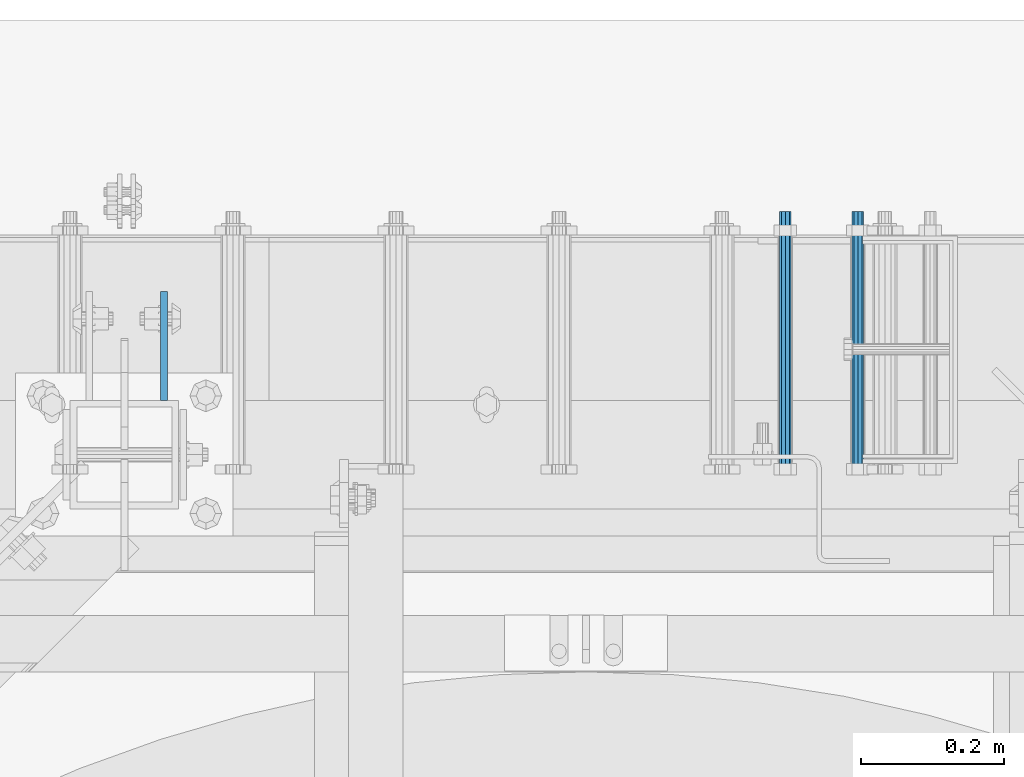
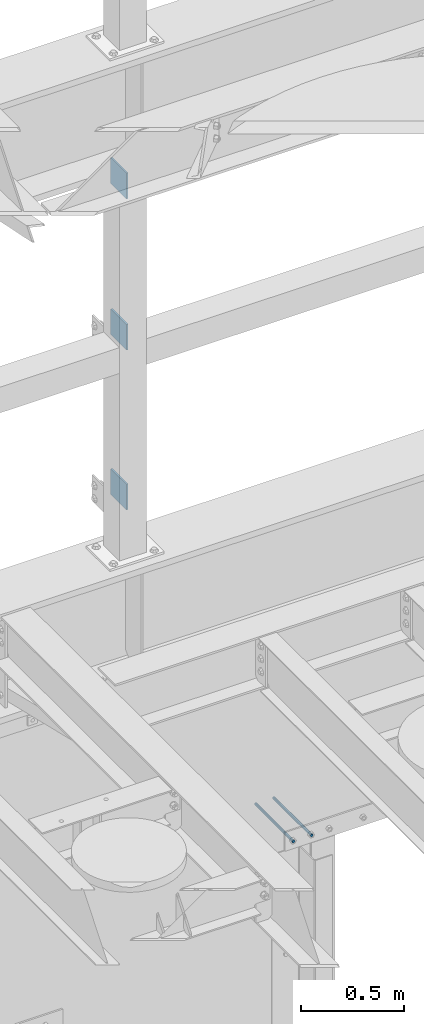
# One storey, part 1322 of 1876: 5 beams, 3 elements without a shape of their own.
"""IFC2X3 building model written with IfcOpenShell, lengths in millimetres."""

from ifc_helpers import new_model, si_unit, frame, origin_with_axes, place, context, subcontext, project, spatial, faceted_brep, material, type_object, element, aggregate, save


model = new_model("IFC2X3")

# Units and contexts
model_context = context("Model", 3, precision=1e-05, world=origin_with_axes())
body_context = subcontext(model_context, "Body", "Model", "MODEL_VIEW")
ifc_project = project(units=[si_unit("LENGTHUNIT", "METRE", prefix="MILLI"), si_unit("AREAUNIT", "SQUARE_METRE"), si_unit("VOLUMEUNIT", "CUBIC_METRE"), si_unit("MASSUNIT", "GRAM", prefix="KILO"), si_unit("TIMEUNIT", "SECOND"), si_unit("PLANEANGLEUNIT", "RADIAN"), si_unit("SOLIDANGLEUNIT", "STERADIAN"), si_unit("THERMODYNAMICTEMPERATUREUNIT", "DEGREE_CELSIUS"), si_unit("LUMINOUSINTENSITYUNIT", "LUMEN")], contexts=[model_context])

# Site, building, storey
site_placement = place(None, origin_with_axes())
site = spatial("IfcSite", under=ifc_project, at=site_placement, CompositionType="ELEMENT")
building_placement = place(site_placement, origin_with_axes())
building = spatial("IfcBuilding", under=site, at=building_placement, Name="Undefined", CompositionType="ELEMENT")
storey_placement = place(building_placement, origin_with_axes())
storey = spatial("IfcBuildingStorey", under=building, at=storey_placement, Name="Undefined", CompositionType="ELEMENT", Elevation=0.0)

# Assembly, beams
assembly_1_placement = place(storey_placement, origin_with_axes())
assembly_1 = element("IfcElementAssembly", 1, at=assembly_1_placement, inside=storey, Name="FRAME", AssemblyPlace="NOTDEFINED", PredefinedType="RIGID_FRAME")
ifc_material = material(Name="STEEL/A36")
beam_type_1 = type_object("IfcBeamType", PredefinedType="NOTDEFINED")
beam_1_placement = place(assembly_1_placement, frame((2595.55129445271, 13792.2, 7226.3), z_axis=(0.0, 0.0, -1.0), x_axis=(0.0, 1.0, 0.0)))
beam_1 = element("IfcBeam", 2, at=beam_1_placement, type_object=beam_type_1, material=ifc_material, Name="PLATE", context=body_context, shape_type="Brep", body=[
    faceted_brep([(0.0, 4.76249999999982, -76.1999999999998), (3.63797880709171e-12, 4.76249999999982, 76.1999969482422), (152.399993896484, 4.76250000000073, 76.1999969482422), (152.4, 4.76249999999982, -76.1999999999998), (3.63797880709171e-12, -4.76249999999982, 76.1999969482422), (152.399993896484, -4.76250000000073, 76.1999969482422), (0.0, -4.76249999999982, -76.1999999999998), (152.4, -4.76249999999982, -76.1999999999998)], [[[0, 1, 2, 3]], [[4, 5, 2, 1]], [[4, 6, 7, 5]], [[6, 0, 3, 7]], [[5, 7, 3, 2]], [[6, 4, 1, 0]]]),
])
beam_2_placement = place(assembly_1_placement, frame((2595.55129445271, 13792.2, 6330.95), z_axis=(0.0, 0.0, -1.0), x_axis=(0.0, 1.0, 0.0)))
beam_2 = element("IfcBeam", 3, at=beam_2_placement, type_object=beam_type_1, material=ifc_material, Name="PLATE", context=body_context, shape_type="Brep", body=[
    faceted_brep([(0.0, 4.76249999999982, -76.1999999999998), (3.63797880709171e-12, 4.76249999999982, 76.1999969482422), (152.399993896484, 4.76250000000073, 76.1999969482422), (152.4, 4.76249999999982, -76.1999999999998), (3.63797880709171e-12, -4.76249999999982, 76.1999969482422), (152.399993896484, -4.76250000000073, 76.1999969482422), (0.0, -4.76249999999982, -76.1999999999998), (152.4, -4.76249999999982, -76.1999999999998)], [[[0, 1, 2, 3]], [[4, 5, 2, 1]], [[4, 6, 7, 5]], [[6, 0, 3, 7]], [[5, 7, 3, 2]], [[6, 4, 1, 0]]]),
])
beam_3_placement = place(assembly_1_placement, frame((2595.55129445271, 13792.2, 5384.8), z_axis=(0.0, 0.0, -1.0), x_axis=(0.0, 1.0, 0.0)))
beam_3 = element("IfcBeam", 4, at=beam_3_placement, type_object=beam_type_1, material=ifc_material, Name="PLATE", context=body_context, shape_type="Brep", body=[
    faceted_brep([(0.0, 4.76249999999982, -76.1999999999998), (3.63797880709171e-12, 4.76249999999982, 76.1999969482422), (152.399993896484, 4.76250000000073, 76.1999969482422), (152.4, 4.76249999999982, -76.1999999999998), (3.63797880709171e-12, -4.76249999999982, 76.1999969482422), (152.399993896484, -4.76250000000073, 76.1999969482422), (0.0, -4.76249999999982, -76.1999999999998), (152.4, -4.76249999999982, -76.1999999999998)], [[[0, 1, 2, 3]], [[4, 5, 2, 1]], [[4, 6, 7, 5]], [[6, 0, 3, 7]], [[5, 7, 3, 2]], [[6, 4, 1, 0]]]),
])
aggregate(assembly_1, [beam_1, beam_2, beam_3])

# Assembly, beam
assembly_2_placement = place(storey_placement, origin_with_axes())
assembly_2 = element("IfcElementAssembly", 5, at=assembly_2_placement, inside=storey, Name="ANCHOR_BOLT", AssemblyPlace="NOTDEFINED", PredefinedType="RIGID_FRAME")
beam_type_2 = type_object("IfcBeamType", PredefinedType="NOTDEFINED")
beam_4_placement = place(assembly_2_placement, frame((3568.71071748669, 14057.3124966791, 3103.56250152592), z_axis=(0.0, 0.0, 1.0), x_axis=(-2.91149999864615e-05, -0.999999999576158, 0.0)))
beam_4 = element("IfcBeam", 6, at=beam_4_placement, type_object=beam_type_2, material=ifc_material, Name="ANCHOR_BOLT", context=body_context, shape_type="Brep", body=[
    faceted_brep([(0.0, -7.9375, 0.0), (0.0, -5.61266007566822, -5.61266007566883), (369.887490732475, -5.61266007567792, -5.61266007566837), (369.887490732477, -7.93750000000978, 0.0), (0.0, 0.0, -7.9375), (369.88749073247, -9.54969436861575e-12, -7.9375), (0.0, 5.61266007566822, -5.61266007566883), (369.887490732464, 5.6126600756586, -5.61266007566837), (0.0, 7.9375, 0.0), (369.887490732463, 7.93749999999045, 0.0), (0.0, 5.61266007566822, 5.61266007566883), (369.887490732464, 5.6126600756586, 5.61266007566837), (0.0, 0.0, 7.9375), (369.88749073247, -9.54969436861575e-12, 7.9375), (0.0, -5.61266007566822, 5.61266007566883), (369.887490732475, -5.61266007567792, 5.61266007566837)], [[[0, 1, 2, 3]], [[1, 4, 5, 2]], [[4, 6, 7, 5]], [[6, 8, 9, 7]], [[8, 10, 11, 9]], [[10, 12, 13, 11]], [[12, 14, 15, 13]], [[14, 0, 3, 15]], [[5, 7, 9, 11, 13, 15, 3, 2]], [[14, 12, 10, 8, 6, 4, 1, 0]]]),
])
aggregate(assembly_2, [beam_4])

assembly_3_placement = place(storey_placement, origin_with_axes())
assembly_3 = element("IfcElementAssembly", 7, at=assembly_3_placement, inside=storey, Name="ANCHOR_BOLT", AssemblyPlace="NOTDEFINED", PredefinedType="RIGID_FRAME")
beam_5_placement = place(assembly_3_placement, frame((3467.11071748669, 14057.3124966791, 3103.56250152592), z_axis=(0.0, 0.0, 1.0), x_axis=(-2.91149999864615e-05, -0.999999999576158, 0.0)))
beam_5 = element("IfcBeam", 8, at=beam_5_placement, type_object=beam_type_2, material=ifc_material, Name="ANCHOR_BOLT", context=body_context, shape_type="Brep", body=[
    faceted_brep([(0.0, -7.9375, 0.0), (0.0, -5.61266007566822, -5.61266007566883), (369.887490732475, -5.61266007567792, -5.61266007566837), (369.887490732477, -7.93750000000978, 0.0), (0.0, 0.0, -7.9375), (369.88749073247, -9.54969436861575e-12, -7.9375), (0.0, 5.61266007566822, -5.61266007566883), (369.887490732464, 5.6126600756586, -5.61266007566837), (0.0, 7.9375, 0.0), (369.887490732463, 7.93749999999045, 0.0), (0.0, 5.61266007566822, 5.61266007566883), (369.887490732464, 5.6126600756586, 5.61266007566837), (0.0, 0.0, 7.9375), (369.88749073247, -9.54969436861575e-12, 7.9375), (0.0, -5.61266007566822, 5.61266007566883), (369.887490732475, -5.61266007567792, 5.61266007566837)], [[[0, 1, 2, 3]], [[1, 4, 5, 2]], [[4, 6, 7, 5]], [[6, 8, 9, 7]], [[8, 10, 11, 9]], [[10, 12, 13, 11]], [[12, 14, 15, 13]], [[14, 0, 3, 15]], [[5, 7, 9, 11, 13, 15, 3, 2]], [[14, 12, 10, 8, 6, 4, 1, 0]]]),
])
aggregate(assembly_3, [beam_5])

save(model, "model.ifc")
